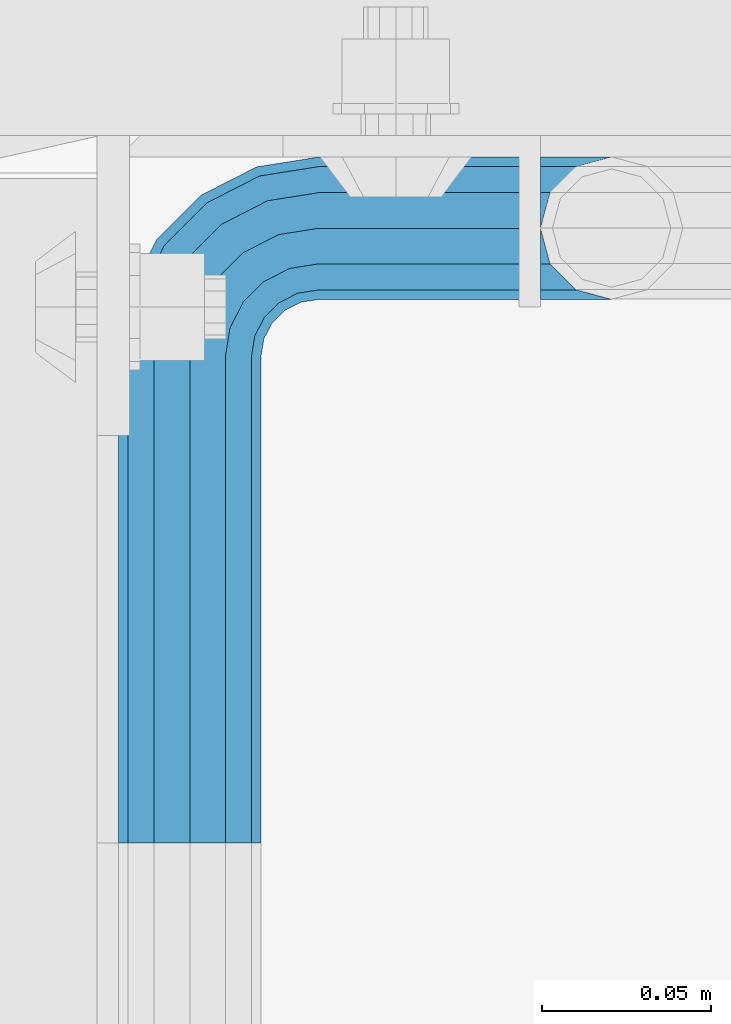
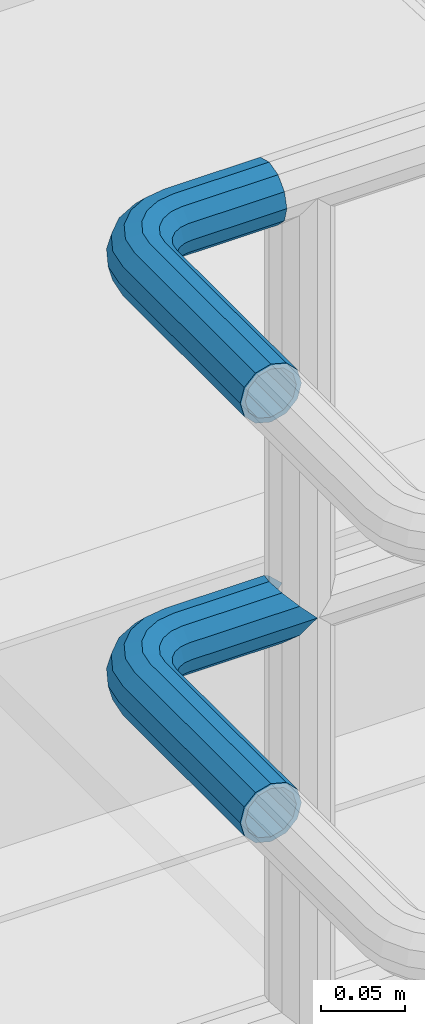
# One storey, part 1116 of 1876: 2 beams, 1 element without a shape of its own.
"""IFC2X3 building model written with IfcOpenShell, lengths in millimetres."""

from ifc_helpers import new_model, si_unit, frame, origin_with_axes, place, context, subcontext, project, spatial, faceted_brep, material, type_object, element, aggregate, save


model = new_model("IFC2X3")

# Units and contexts
model_context = context("Model", 3, precision=1e-05, world=origin_with_axes())
body_context = subcontext(model_context, "Body", "Model", "MODEL_VIEW")
ifc_project = project(units=[si_unit("LENGTHUNIT", "METRE", prefix="MILLI"), si_unit("AREAUNIT", "SQUARE_METRE"), si_unit("VOLUMEUNIT", "CUBIC_METRE"), si_unit("MASSUNIT", "GRAM", prefix="KILO"), si_unit("TIMEUNIT", "SECOND"), si_unit("PLANEANGLEUNIT", "RADIAN"), si_unit("SOLIDANGLEUNIT", "STERADIAN"), si_unit("THERMODYNAMICTEMPERATUREUNIT", "DEGREE_CELSIUS"), si_unit("LUMINOUSINTENSITYUNIT", "LUMEN")], contexts=[model_context])

# Site, building, storey
site_placement = place(None, origin_with_axes())
site = spatial("IfcSite", under=ifc_project, at=site_placement, CompositionType="ELEMENT")
building_placement = place(site_placement, origin_with_axes())
building = spatial("IfcBuilding", under=site, at=building_placement, Name="Undefined", CompositionType="ELEMENT")
storey_placement = place(building_placement, origin_with_axes())
storey = spatial("IfcBuildingStorey", under=building, at=storey_placement, Name="Undefined", CompositionType="ELEMENT", Elevation=0.0)

# Assembly, beams
assembly_placement = place(storey_placement, origin_with_axes())
assembly = element("IfcElementAssembly", 1, at=assembly_placement, inside=storey, Name="HANDRAIL", AssemblyPlace="NOTDEFINED", PredefinedType="RIGID_FRAME")
ifc_material = material()
beam_type = type_object("IfcBeamType", Name="PIPE1-1/4STD", PredefinedType="NOTDEFINED")
beam_1_placement = place(assembly_placement, frame((5666.23343150122, -11563.31485742, 8785.225), z_axis=(0.0, 0.0, -1.0), x_axis=(0.0, 1.0, 0.0)))
beam_1 = element("IfcBeam", 2, at=beam_1_placement, type_object=beam_type, material=ifc_material, Name="HANDRAIL", ObjectType="PIPE1-1/4STD", context=body_context, shape_type="Brep", body=[
    faceted_brep([(192.588302246095, 106.710451704997, 18.2575475625836), (192.588309811317, 106.710451704997, 13.3999536615011), (190.810302246095, 106.234036013759, 15.1779612267255), (182.047302246094, 103.88599926758, 17.5259999999998), (182.047302246094, 103.88599926758, 21.0820000000003), (173.284302246095, 106.23404006795, 15.1779612267255), (171.506309811319, 106.710451704997, 13.3999687919495), (171.506302246094, 106.710451704997, 18.2575475625836), (163.78975468351, 114.42699926758, 10.5409999999993), (163.78975468351, 114.42699926758, -10.5409999999993), (160.965302246093, 124.968002319336, 0.0), (166.869341019368, 111.347420496947, 8.76300000000083), (164.521302246094, 113.69545927022, 0.0), (166.869341019368, 111.347420496947, -8.76300000000083), (171.506309811319, 106.710451704997, -13.3999687919495), (171.506302246094, 106.710451704997, -18.2575475625836), (182.047302246094, 103.88599926758, -17.5259999999998), (182.047302246094, 103.88599926758, -21.0820000000003), (173.284302246095, 106.23404006795, -15.1779612267255), (192.588309811317, 106.710451704997, -13.3999536615011), (192.588302246095, 106.710451704997, -18.2575475625836), (190.810302246095, 106.234036013759, -15.1779612267255), (203.129309811318, 124.96799926758, 0.0), (200.304849808677, 114.42699926758, -10.5409999999993), (200.304849808677, 114.42699926758, 10.5409999999993), (197.225263472819, 111.347405366499, -8.76300000000083), (199.573302246094, 113.695444139772, 0.0), (197.225263472819, 111.347405366499, 8.76300000000083), (0.0, -18.2575475625836, -10.5409999999993), (0.0, -10.5410000000002, -18.2575475625836), (143.947303771973, -10.5409999999983, -18.2575475625836), (143.947303771973, -18.2575475625817, -10.5409999999993), (-4.28826751885936e-09, 0.0, -21.0820000000003), (143.947303771973, 1.81898940354586e-12, -21.0820000000003), (0.0, 10.5410000000002, -18.2575475625836), (143.947303771973, 10.5410000000011, -18.2575475625836), (0.0, 18.2575475625836, -10.5409999999993), (143.947303771973, 18.2575475625854, -10.5409999999993), (9.09494701772928e-13, 21.0820000000003, 0.0), (143.947303771973, 21.0820000000012, 0.0), (0.0, 18.2575475625836, 10.5409999999993), (143.947303771973, 18.2575475625854, 10.5409999999993), (0.0, 10.5410000000002, 18.2575475625836), (143.947303771973, 10.5410000000011, 18.2575475625836), (0.0, 0.0, 21.0820000000003), (143.947303771973, 1.81898940354586e-12, 21.0820000000003), (0.0, -10.5410000000002, 18.2575475625836), (143.947303771973, -10.5409999999983, 18.2575475625836), (0.0, -18.2575475625836, 10.5409999999993), (143.947303771973, -18.2575475625817, 10.5409999999993), (9.09494701772928e-13, -21.0820000000003, 0.0), (143.947303771973, -21.0819999999985, 0.0), (162.235547061553, -18.1854268220586, 0.0), (161.362743258587, -15.4992129264883, 10.5409999999993), (158.978198923845, -8.16034008379211, 18.2575475625836), (155.720850786138, 1.86474665447531, 21.0820000000003), (152.463502648432, 11.8898333927418, 18.2575475625836), (150.07895831369, 19.228706235438, 10.5409999999993), (149.206154510724, 21.9149201310092, 0.0), (150.07895831369, 19.2287062354389, -10.5409999999993), (152.463502648432, 11.8898333927418, -18.2575475625836), (155.720850786138, 1.86474665447531, -21.0820000000003), (158.978198923845, -8.16034008379211, -18.2575475625836), (161.362743258587, -15.4992129264883, -10.5409999999993), (163.789754683512, 38.0999984741229, -10.5409999999993), (160.965302246095, 38.0999984741229, 0.0), (163.789754683512, 38.0999984741229, 10.5409999999993), (171.506302246096, 38.0999984741229, 18.2575475625836), (182.047302246096, 38.099998474122, 21.0820000000003), (192.588302246097, 38.099998474122, 18.2575475625836), (200.304849808679, 38.099998474122, 10.5409999999993), (203.129302246094, 38.0999984741229, 0.0), (182.047302246096, 38.099998474122, -21.0820000000003), (171.506302246096, 38.0999984741229, -18.2575475625836), (192.588302246095, 38.099998474122, -18.2575475625836), (200.304849808679, 38.099998474122, -10.5409999999993), (162.818596010658, 31.9683439324062, -10.5409999999993), (170.157468853355, 29.5837995976653, -18.2575475625836), (160.132382115087, 32.841147735372, 0.0), (162.818596010658, 31.9683439324062, 10.5409999999993), (170.157468853355, 29.5837995976653, 18.2575475625836), (180.182555591622, 26.3264514599587, 21.0820000000003), (190.207642329889, 23.069103322252, 18.2575475625836), (197.546515172586, 20.6845589875102, 10.5409999999993), (200.232729068157, 19.8117551845444, 0.0), (197.546515172586, 20.6845589875102, -10.5409999999993), (190.207642329889, 23.069103322252, -18.2575475625836), (180.182555591622, 26.3264514599587, -21.0820000000003), (166.243001885488, 21.9012256030801, -18.2575475625836), (174.770850023195, 15.7053812586637, -21.0820000000003), (160.000183769456, 26.436898458981, -10.5409999999993), (157.715153747784, 28.0970699474965, 0.0), (160.000183769456, 26.436898458981, 10.5409999999993), (166.243001885488, 21.9012256030801, 18.2575475625836), (174.770850023195, 15.7053812586637, 21.0820000000003), (183.298698160899, 9.50953691424729, 18.2575475625836), (189.541516276931, 4.97386405834641, 10.5409999999993), (191.826546298606, 3.31369256983089, 0.0), (189.541516276931, 4.97386405834641, -10.5409999999993), (183.298698160899, 9.50953691424729, -18.2575475625836), (166.341920987434, 7.27645222290266, -21.0820000000003), (172.53776533185, -1.25139591480183, -18.2575475625836), (160.146076643017, 15.8043003606081, -18.2575475625836), (155.610403787116, 22.0471184766402, -10.5409999999993), (153.950232298601, 24.3321484983135, 0.0), (155.610403787116, 22.0471184766402, 10.5409999999993), (160.146076643017, 15.8043003606081, 18.2575475625836), (166.341920987434, 7.27645222290266, 21.0820000000003), (172.53776533185, -1.25139591480183, 18.2575475625836), (177.07343818775, -7.49421403083397, 10.5409999999993), (178.733609676266, -9.77924405250724, 0.0), (177.07343818775, -7.49421403083397, -10.5409999999993), (0.0, -15.1779612267264, -8.76300000000083), (0.0, -8.76299999999992, -15.1779612267255), (0.0, 0.0, -17.5259999999998), (0.0, 8.76299999999992, -15.1779612267255), (0.0, 15.1779612267264, -8.76300000000083), (0.0, 17.5259999999998, 0.0), (0.0, 15.1779612267264, 8.76300000000083), (0.0, 8.76299999999992, 15.1779612267255), (0.0, 0.0, 17.5259999999998), (0.0, -8.76299999999992, 15.1779612267255), (0.0, -15.1779612267264, 8.76300000000083), (0.0, -17.5259999999998, 0.0), (143.947303771973, -8.7629999999981, 15.1779612267255), (143.947303771973, -15.1779612267246, 8.76300000000083), (143.947303771973, -17.5259999999989, 0.0), (143.947303771973, -15.1779612267246, -8.76300000000083), (143.947303771973, -8.76299999999901, -15.1779612267255), (143.947303771973, 1.81898940354586e-12, -17.5259999999998), (143.947303771973, 8.76300000000174, -15.1779612267255), (143.947303771973, 15.1779612267273, -8.76300000000083), (143.947303771973, 17.5260000000017, 0.0), (143.947303771973, 15.1779612267273, 8.76300000000083), (143.947303771973, 8.76300000000174, 15.1779612267255), (143.947303771973, 1.81898940354586e-12, 17.5259999999998), (155.720850786138, 1.86474665447531, 17.5259999999998), (158.428766707846, -6.46936159781944, 15.1779612267255), (160.411098745162, -12.5703522742779, 8.76300000000083), (161.136682629554, -14.8034698501133, 0.0), (160.411098745162, -12.5703522742779, -8.76300000000083), (158.428766707846, -6.46936159781944, -15.1779612267255), (155.720850786138, 1.86474665447531, -17.5259999999998), (153.01293486443, 10.1988549067692, -15.1779612267255), (151.030602827115, 16.2998455832276, -8.76300000000083), (150.305018942723, 18.5329631590639, 0.0), (151.030602827115, 16.2998455832276, 8.76300000000083), (153.01293486443, 10.1988549067692, 15.1779612267255), (161.191158821593, 14.3658681446095, 15.1779612267255), (166.341920987434, 7.27645222290266, 17.5259999999998), (157.420539218494, 19.5556807952871, 8.76300000000083), (156.040396655753, 21.4552840663164, 0.0), (157.420539218494, 19.5556807952871, -8.76300000000083), (161.191158821593, 14.3658681446095, -15.1779612267255), (166.341920987434, 7.27645222290266, -17.5259999999998), (171.492683153274, 0.187036301196713, -15.1779612267255), (175.263302756372, -5.00277634948088, -8.76300000000083), (176.643445319114, -6.90237962051015, 0.0), (175.263302756372, -5.00277634948088, 8.76300000000083), (171.492683153274, 0.187036301196713, 15.1779612267255), (174.770850023195, 15.7053812586637, 17.5259999999998), (181.860265944901, 10.5546190928235, 15.1779612267255), (167.681434101487, 20.8561434245039, 15.1779612267255), (162.49162145081, 24.6267630276025, 8.76300000000083), (160.592018179781, 26.0069055903441, 0.0), (162.49162145081, 24.6267630276025, -8.76300000000083), (167.681434101487, 20.8561434245039, -15.1779612267255), (174.770850023195, 15.7053812586637, -17.5259999999998), (181.860265944901, 10.5546190928235, -15.1779612267255), (187.050078595577, 6.78399948972492, -8.76300000000083), (188.949681866608, 5.40385692698328, 0.0), (187.050078595577, 6.78399948972492, 8.76300000000083), (188.516663843917, 23.6185355382504, 15.1779612267255), (194.617654520374, 21.6362035009352, 8.76300000000083), (180.182555591622, 26.3264514599587, 17.5259999999998), (171.848447339327, 29.0343673816669, 15.1779612267255), (165.74745666287, 31.0166994189813, 8.76300000000083), (163.514339087033, 31.7422833033743, 0.0), (165.74745666287, 31.0166994189813, -8.76300000000083), (171.848447339327, 29.0343673816669, -15.1779612267255), (180.182555591622, 26.3264514599587, -17.5259999999998), (188.516663843917, 23.6185355382504, -15.1779612267255), (194.617654520374, 21.6362035009352, -8.76300000000083), (196.850772096212, 20.9106196165421, 0.0), (197.225263472821, 38.099998474122, 8.76300000000083), (199.573302246094, 38.0999984741229, 0.0), (190.810302246096, 38.099998474122, 15.1779612267255), (182.047302246096, 38.099998474122, 17.5259999999998), (173.284302246095, 38.099998474122, 15.1779612267255), (166.86934101937, 38.0999984741229, 8.76300000000083), (164.521302246096, 38.0999984741229, 0.0), (166.86934101937, 38.0999984741229, -8.76300000000083), (173.284302246095, 38.099998474122, -15.1779612267255), (182.047302246096, 38.099998474122, -17.5259999999998), (190.810302246096, 38.099998474122, -15.1779612267255), (197.225263472821, 38.099998474122, -8.76300000000083)], [[[0, 1, 2, 3, 4]], [[4, 3, 5, 6, 7]], [[8, 9, 10]], [[7, 6, 11, 12, 13, 14, 15, 9, 8]], [[16, 17, 15, 14, 18]], [[19, 20, 17, 16, 21]], [[22, 23, 24]], [[24, 23, 20, 19, 25, 26, 27, 1, 0]], [[28, 29, 30, 31]], [[29, 32, 33, 30]], [[32, 34, 35, 33]], [[34, 36, 37, 35]], [[36, 38, 39, 37]], [[38, 40, 41, 39]], [[40, 42, 43, 41]], [[42, 44, 45, 43]], [[44, 46, 47, 45]], [[46, 48, 49, 47]], [[48, 50, 51, 49]], [[49, 51, 52, 53]], [[47, 49, 53, 54]], [[45, 47, 54, 55]], [[43, 45, 55, 56]], [[41, 43, 56, 57]], [[39, 41, 57, 58]], [[37, 39, 58, 59]], [[35, 37, 59, 60]], [[33, 35, 60, 61]], [[30, 33, 61, 62]], [[31, 30, 62, 63]], [[64, 65, 10, 9]], [[65, 66, 8, 10]], [[66, 67, 7, 8]], [[67, 68, 4, 7]], [[68, 69, 0, 4]], [[69, 70, 24, 0]], [[70, 71, 22, 24]], [[72, 73, 15, 17]], [[74, 72, 17, 20]], [[75, 74, 20, 23]], [[71, 75, 23, 22]], [[73, 64, 9, 15]], [[76, 64, 73, 77]], [[78, 65, 64, 76]], [[79, 66, 65, 78]], [[80, 67, 66, 79]], [[81, 68, 67, 80]], [[82, 69, 68, 81]], [[83, 70, 69, 82]], [[84, 71, 70, 83]], [[85, 75, 71, 84]], [[86, 74, 75, 85]], [[87, 72, 74, 86]], [[77, 73, 72, 87]], [[88, 77, 87, 89]], [[90, 76, 77, 88]], [[91, 78, 76, 90]], [[92, 79, 78, 91]], [[93, 80, 79, 92]], [[94, 81, 80, 93]], [[95, 82, 81, 94]], [[96, 83, 82, 95]], [[97, 84, 83, 96]], [[98, 85, 84, 97]], [[99, 86, 85, 98]], [[89, 87, 86, 99]], [[100, 89, 99, 101]], [[102, 88, 89, 100]], [[103, 90, 88, 102]], [[104, 91, 90, 103]], [[105, 92, 91, 104]], [[106, 93, 92, 105]], [[107, 94, 93, 106]], [[108, 95, 94, 107]], [[109, 96, 95, 108]], [[110, 97, 96, 109]], [[111, 98, 97, 110]], [[101, 99, 98, 111]], [[62, 101, 111, 63]], [[61, 100, 101, 62]], [[60, 102, 100, 61]], [[59, 103, 102, 60]], [[58, 104, 103, 59]], [[57, 105, 104, 58]], [[56, 106, 105, 57]], [[55, 107, 106, 56]], [[54, 108, 107, 55]], [[53, 109, 108, 54]], [[52, 110, 109, 53]], [[63, 111, 110, 52]], [[51, 31, 63, 52]], [[50, 28, 31, 51]], [[48, 46, 44, 42, 40, 38, 36, 34, 32, 29, 28, 50], [112, 113, 114, 115, 116, 117, 118, 119, 120, 121, 122, 123]], [[122, 121, 124, 125]], [[123, 122, 125, 126]], [[112, 123, 126, 127]], [[113, 112, 127, 128]], [[114, 113, 128, 129]], [[115, 114, 129, 130]], [[116, 115, 130, 131]], [[117, 116, 131, 132]], [[118, 117, 132, 133]], [[119, 118, 133, 134]], [[120, 119, 134, 135]], [[121, 120, 135, 124]], [[124, 135, 136, 137]], [[125, 124, 137, 138]], [[126, 125, 138, 139]], [[127, 126, 139, 140]], [[128, 127, 140, 141]], [[129, 128, 141, 142]], [[130, 129, 142, 143]], [[131, 130, 143, 144]], [[132, 131, 144, 145]], [[133, 132, 145, 146]], [[134, 133, 146, 147]], [[135, 134, 147, 136]], [[147, 148, 149, 136]], [[146, 150, 148, 147]], [[145, 151, 150, 146]], [[144, 152, 151, 145]], [[143, 153, 152, 144]], [[142, 154, 153, 143]], [[141, 155, 154, 142]], [[140, 156, 155, 141]], [[139, 157, 156, 140]], [[138, 158, 157, 139]], [[137, 159, 158, 138]], [[136, 149, 159, 137]], [[149, 160, 161, 159]], [[148, 162, 160, 149]], [[150, 163, 162, 148]], [[151, 164, 163, 150]], [[152, 165, 164, 151]], [[153, 166, 165, 152]], [[154, 167, 166, 153]], [[155, 168, 167, 154]], [[156, 169, 168, 155]], [[157, 170, 169, 156]], [[158, 171, 170, 157]], [[159, 161, 171, 158]], [[161, 172, 173, 171]], [[160, 174, 172, 161]], [[162, 175, 174, 160]], [[163, 176, 175, 162]], [[164, 177, 176, 163]], [[165, 178, 177, 164]], [[166, 179, 178, 165]], [[167, 180, 179, 166]], [[168, 181, 180, 167]], [[169, 182, 181, 168]], [[170, 183, 182, 169]], [[171, 173, 183, 170]], [[173, 184, 185, 183]], [[172, 186, 184, 173]], [[174, 187, 186, 172]], [[175, 188, 187, 174]], [[176, 189, 188, 175]], [[177, 190, 189, 176]], [[178, 191, 190, 177]], [[179, 192, 191, 178]], [[180, 193, 192, 179]], [[181, 194, 193, 180]], [[182, 195, 194, 181]], [[183, 185, 195, 182]], [[195, 185, 26, 25]], [[21, 194, 195, 25, 19]], [[193, 194, 21, 16]], [[192, 193, 16, 18]], [[13, 191, 192, 18, 14]], [[190, 191, 13, 12]], [[189, 190, 12, 11]], [[188, 189, 11, 6, 5]], [[187, 188, 5, 3]], [[186, 187, 3, 2]], [[184, 186, 2, 1, 27]], [[185, 184, 27, 26]]]),
])
beam_2_placement = place(assembly_placement, frame((5666.23343150122, -11563.31485742, 9090.025), z_axis=(0.0, 0.0, -1.0), x_axis=(0.0, 1.0, 0.0)))
beam_2 = element("IfcBeam", 3, at=beam_2_placement, type_object=beam_type, material=ifc_material, Name="HANDRAIL", ObjectType="PIPE1-1/4STD", context=body_context, shape_type="Brep", body=[
    faceted_brep([(9.09494701772928e-13, -21.0820000000003, 0.0), (0.0, -18.2575475625836, -10.5409999999993), (143.947303771973, -18.2575475625817, -10.5409999999993), (143.947303771973, -21.0819999999985, 0.0), (0.0, -10.5410000000002, -18.2575475625836), (143.947303771973, -10.5409999999983, -18.2575475625836), (-4.28826751885936e-09, 0.0, -21.0820000000003), (143.947303771973, 1.81898940354586e-12, -21.0820000000003), (0.0, 10.5410000000002, -18.2575475625836), (143.947303771973, 10.5410000000011, -18.2575475625836), (0.0, 18.2575475625836, -10.5409999999993), (143.947303771973, 18.2575475625854, -10.5409999999993), (9.09494701772928e-13, 21.0820000000003, 0.0), (143.947303771973, 21.0820000000012, 0.0), (0.0, 18.2575475625836, 10.5409999999993), (143.947303771973, 18.2575475625854, 10.5409999999993), (0.0, 10.5410000000002, 18.2575475625836), (143.947303771973, 10.5410000000011, 18.2575475625836), (0.0, 0.0, 21.0820000000003), (143.947303771973, 1.81898940354586e-12, 21.0820000000003), (0.0, -10.5410000000002, 18.2575475625836), (143.947303771973, -10.5409999999983, 18.2575475625836), (0.0, -18.2575475625836, 10.5409999999993), (143.947303771973, -18.2575475625817, 10.5409999999993), (0.0, -17.5259999999998, 0.0), (0.0, -15.1779612267264, 8.76300000000083), (143.947303771973, -15.1779612267246, 8.76300000000083), (143.947303771973, -17.5259999999989, 0.0), (0.0, -8.76299999999992, 15.1779612267255), (143.947303771973, -8.7629999999981, 15.1779612267255), (0.0, 0.0, 17.5259999999998), (143.947303771973, 1.81898940354586e-12, 17.5259999999998), (0.0, 8.76299999999992, 15.1779612267255), (143.947303771973, 8.76300000000174, 15.1779612267255), (0.0, 15.1779612267264, 8.76300000000083), (143.947303771973, 15.1779612267273, 8.76300000000083), (0.0, 17.5259999999998, 0.0), (143.947303771973, 17.5260000000017, 0.0), (0.0, 15.1779612267264, -8.76300000000083), (143.947303771973, 15.1779612267273, -8.76300000000083), (0.0, 8.76299999999992, -15.1779612267255), (143.947303771973, 8.76300000000174, -15.1779612267255), (0.0, 0.0, -17.5259999999998), (143.947303771973, 1.81898940354586e-12, -17.5259999999998), (0.0, -8.76299999999992, -15.1779612267255), (143.947303771973, -8.76299999999901, -15.1779612267255), (0.0, -15.1779612267264, -8.76300000000083), (143.947303771973, -15.1779612267246, -8.76300000000083), (162.235547061553, -18.1854268220586, 0.0), (161.362743258587, -15.4992129264883, 10.5409999999993), (158.978198923845, -8.16034008379211, 18.2575475625836), (155.720850786138, 1.86474665447531, 21.0820000000003), (152.463502648432, 11.8898333927418, 18.2575475625836), (150.07895831369, 19.228706235438, 10.5409999999993), (149.206154510724, 21.9149201310092, 0.0), (150.07895831369, 19.2287062354389, -10.5409999999993), (152.463502648432, 11.8898333927418, -18.2575475625836), (155.720850786138, 1.86474665447531, -21.0820000000003), (158.978198923845, -8.16034008379211, -18.2575475625836), (161.362743258587, -15.4992129264883, -10.5409999999993), (161.136682629554, -14.8034698501133, 0.0), (160.411098745162, -12.5703522742779, -8.76300000000083), (158.428766707846, -6.46936159781944, -15.1779612267255), (155.720850786138, 1.86474665447531, -17.5259999999998), (153.01293486443, 10.1988549067692, -15.1779612267255), (151.030602827115, 16.2998455832276, -8.76300000000083), (150.305018942723, 18.5329631590639, 0.0), (151.030602827115, 16.2998455832276, 8.76300000000083), (153.01293486443, 10.1988549067692, 15.1779612267255), (155.720850786138, 1.86474665447531, 17.5259999999998), (158.428766707846, -6.46936159781944, 15.1779612267255), (160.411098745162, -12.5703522742779, 8.76300000000083), (172.53776533185, -1.25139591480183, -18.2575475625836), (177.07343818775, -7.49421403083397, -10.5409999999993), (166.341920987434, 7.27645222290266, -21.0820000000003), (160.146076643017, 15.8043003606081, -18.2575475625836), (155.610403787116, 22.0471184766402, -10.5409999999993), (153.950232298601, 24.3321484983135, 0.0), (155.610403787116, 22.0471184766402, 10.5409999999993), (160.146076643017, 15.8043003606081, 18.2575475625836), (166.341920987434, 7.27645222290266, 21.0820000000003), (172.53776533185, -1.25139591480183, 18.2575475625836), (177.07343818775, -7.49421403083397, 10.5409999999993), (178.733609676266, -9.77924405250724, 0.0), (175.263302756372, -5.00277634948088, 8.76300000000083), (176.643445319114, -6.90237962051015, 0.0), (171.492683153274, 0.187036301196713, 15.1779612267255), (166.341920987434, 7.27645222290266, 17.5259999999998), (161.191158821593, 14.3658681446095, 15.1779612267255), (157.420539218494, 19.5556807952871, 8.76300000000083), (156.040396655753, 21.4552840663164, 0.0), (157.420539218494, 19.5556807952871, -8.76300000000083), (161.191158821593, 14.3658681446095, -15.1779612267255), (166.341920987434, 7.27645222290266, -17.5259999999998), (171.492683153274, 0.187036301196713, -15.1779612267255), (175.263302756372, -5.00277634948088, -8.76300000000083), (183.298698160899, 9.50953691424729, -18.2575475625836), (189.541516276931, 4.97386405834641, -10.5409999999993), (174.770850023195, 15.7053812586637, -21.0820000000003), (166.243001885488, 21.9012256030801, -18.2575475625836), (160.000183769456, 26.436898458981, -10.5409999999993), (157.715153747784, 28.0970699474965, 0.0), (160.000183769456, 26.436898458981, 10.5409999999993), (166.243001885488, 21.9012256030801, 18.2575475625836), (174.770850023195, 15.7053812586637, 21.0820000000003), (183.298698160899, 9.50953691424729, 18.2575475625836), (189.541516276931, 4.97386405834641, 10.5409999999993), (191.826546298606, 3.31369256983089, 0.0), (187.050078595577, 6.78399948972492, 8.76300000000083), (188.949681866608, 5.40385692698328, 0.0), (181.860265944901, 10.5546190928235, 15.1779612267255), (174.770850023195, 15.7053812586637, 17.5259999999998), (167.681434101487, 20.8561434245039, 15.1779612267255), (162.49162145081, 24.6267630276025, 8.76300000000083), (160.592018179781, 26.0069055903441, 0.0), (162.49162145081, 24.6267630276025, -8.76300000000083), (167.681434101487, 20.8561434245039, -15.1779612267255), (174.770850023195, 15.7053812586637, -17.5259999999998), (181.860265944901, 10.5546190928235, -15.1779612267255), (187.050078595577, 6.78399948972492, -8.76300000000083), (190.207642329889, 23.069103322252, -18.2575475625836), (197.546515172586, 20.6845589875102, -10.5409999999993), (180.182555591622, 26.3264514599587, -21.0820000000003), (170.157468853355, 29.5837995976653, -18.2575475625836), (162.818596010658, 31.9683439324062, -10.5409999999993), (160.132382115087, 32.841147735372, 0.0), (162.818596010658, 31.9683439324062, 10.5409999999993), (170.157468853355, 29.5837995976653, 18.2575475625836), (180.182555591622, 26.3264514599587, 21.0820000000003), (190.207642329889, 23.069103322252, 18.2575475625836), (197.546515172586, 20.6845589875102, 10.5409999999993), (200.232729068157, 19.8117551845444, 0.0), (194.617654520374, 21.6362035009352, 8.76300000000083), (196.850772096212, 20.9106196165421, 0.0), (188.516663843917, 23.6185355382504, 15.1779612267255), (180.182555591622, 26.3264514599587, 17.5259999999998), (171.848447339327, 29.0343673816669, 15.1779612267255), (165.74745666287, 31.0166994189813, 8.76300000000083), (163.514339087033, 31.7422833033743, 0.0), (165.74745666287, 31.0166994189813, -8.76300000000083), (171.848447339327, 29.0343673816669, -15.1779612267255), (180.182555591622, 26.3264514599587, -17.5259999999998), (188.516663843917, 23.6185355382504, -15.1779612267255), (194.617654520374, 21.6362035009352, -8.76300000000083), (192.588302246095, 38.099998474122, -18.2575475625836), (200.304849808679, 38.099998474122, -10.5409999999993), (182.047302246096, 38.099998474122, -21.0820000000003), (171.506302246096, 38.0999984741229, -18.2575475625836), (163.789754683512, 38.0999984741229, -10.5409999999993), (160.965302246095, 38.0999984741229, 0.0), (163.789754683512, 38.0999984741229, 10.5409999999993), (171.506302246096, 38.0999984741229, 18.2575475625836), (182.047302246096, 38.099998474122, 21.0820000000003), (192.588302246097, 38.099998474122, 18.2575475625836), (200.304849808679, 38.099998474122, 10.5409999999993), (203.129302246094, 38.0999984741229, 0.0), (197.225263472821, 38.099998474122, 8.76300000000083), (199.573302246094, 38.0999984741229, 0.0), (190.810302246096, 38.099998474122, 15.1779612267255), (182.047302246096, 38.099998474122, 17.5259999999998), (173.284302246095, 38.099998474122, 15.1779612267255), (166.86934101937, 38.0999984741229, 8.76300000000083), (164.521302246096, 38.0999984741229, 0.0), (166.86934101937, 38.0999984741229, -8.76300000000083), (173.284302246095, 38.099998474122, -15.1779612267255), (182.047302246096, 38.099998474122, -17.5259999999998), (190.810302246096, 38.099998474122, -15.1779612267255), (197.225263472821, 38.099998474122, -8.76300000000083), (200.304849808677, 103.933624267578, -10.5409999999993), (203.129302246094, 103.933624267578, 0.0), (192.588302246093, 103.933624267578, -18.2575475625836), (182.047302246094, 103.933624267578, -21.0820000000003), (171.506302246094, 103.933624267578, -18.2575475625836), (163.78975468351, 103.933624267578, -10.5409999999993), (160.965302246093, 103.933624267578, 0.0), (163.78975468351, 103.933624267578, 10.5409999999993), (171.506302246094, 103.933624267578, 18.2575475625836), (182.047302246094, 103.933624267578, 21.0820000000003), (192.588302246093, 103.933624267578, 18.2575475625836), (200.304849808677, 103.933624267578, 10.5409999999993), (197.225263472819, 103.933624267578, 8.76300000000083), (199.573302246094, 103.933624267578, 0.0), (190.810302246095, 103.933624267578, 15.1779612267255), (182.047302246094, 103.933624267578, 17.5259999999998), (173.284302246093, 103.933624267578, 15.1779612267255), (166.869341019368, 103.933624267578, 8.76300000000083), (164.521302246094, 103.933624267578, 0.0), (166.869341019368, 103.933624267578, -8.76300000000083), (173.284302246093, 103.933624267578, -15.1779612267255), (182.047302246094, 103.933624267578, -17.5259999999998), (190.810302246095, 103.933624267578, -15.1779612267255), (197.225263472819, 103.933624267578, -8.76300000000083)], [[[0, 1, 2, 3]], [[1, 4, 5, 2]], [[4, 6, 7, 5]], [[6, 8, 9, 7]], [[8, 10, 11, 9]], [[10, 12, 13, 11]], [[12, 14, 15, 13]], [[14, 16, 17, 15]], [[16, 18, 19, 17]], [[18, 20, 21, 19]], [[20, 22, 23, 21]], [[22, 0, 3, 23]], [[24, 25, 26, 27]], [[25, 28, 29, 26]], [[28, 30, 31, 29]], [[30, 32, 33, 31]], [[32, 34, 35, 33]], [[34, 36, 37, 35]], [[36, 38, 39, 37]], [[38, 40, 41, 39]], [[40, 42, 43, 41]], [[42, 44, 45, 43]], [[44, 46, 47, 45]], [[46, 24, 27, 47]], [[22, 20, 18, 16, 14, 12, 10, 8, 6, 4, 1, 0], [46, 44, 42, 40, 38, 36, 34, 32, 30, 28, 25, 24]], [[23, 3, 48, 49]], [[21, 23, 49, 50]], [[19, 21, 50, 51]], [[17, 19, 51, 52]], [[15, 17, 52, 53]], [[13, 15, 53, 54]], [[11, 13, 54, 55]], [[9, 11, 55, 56]], [[7, 9, 56, 57]], [[5, 7, 57, 58]], [[2, 5, 58, 59]], [[3, 2, 59, 48]], [[47, 27, 60, 61]], [[45, 47, 61, 62]], [[43, 45, 62, 63]], [[41, 43, 63, 64]], [[39, 41, 64, 65]], [[37, 39, 65, 66]], [[35, 37, 66, 67]], [[33, 35, 67, 68]], [[31, 33, 68, 69]], [[29, 31, 69, 70]], [[26, 29, 70, 71]], [[27, 26, 71, 60]], [[58, 72, 73, 59]], [[57, 74, 72, 58]], [[56, 75, 74, 57]], [[55, 76, 75, 56]], [[54, 77, 76, 55]], [[53, 78, 77, 54]], [[52, 79, 78, 53]], [[51, 80, 79, 52]], [[50, 81, 80, 51]], [[49, 82, 81, 50]], [[48, 83, 82, 49]], [[59, 73, 83, 48]], [[71, 84, 85, 60]], [[70, 86, 84, 71]], [[69, 87, 86, 70]], [[68, 88, 87, 69]], [[67, 89, 88, 68]], [[66, 90, 89, 67]], [[65, 91, 90, 66]], [[64, 92, 91, 65]], [[63, 93, 92, 64]], [[62, 94, 93, 63]], [[61, 95, 94, 62]], [[60, 85, 95, 61]], [[72, 96, 97, 73]], [[74, 98, 96, 72]], [[75, 99, 98, 74]], [[76, 100, 99, 75]], [[77, 101, 100, 76]], [[78, 102, 101, 77]], [[79, 103, 102, 78]], [[80, 104, 103, 79]], [[81, 105, 104, 80]], [[82, 106, 105, 81]], [[83, 107, 106, 82]], [[73, 97, 107, 83]], [[84, 108, 109, 85]], [[86, 110, 108, 84]], [[87, 111, 110, 86]], [[88, 112, 111, 87]], [[89, 113, 112, 88]], [[90, 114, 113, 89]], [[91, 115, 114, 90]], [[92, 116, 115, 91]], [[93, 117, 116, 92]], [[94, 118, 117, 93]], [[95, 119, 118, 94]], [[85, 109, 119, 95]], [[96, 120, 121, 97]], [[98, 122, 120, 96]], [[99, 123, 122, 98]], [[100, 124, 123, 99]], [[101, 125, 124, 100]], [[102, 126, 125, 101]], [[103, 127, 126, 102]], [[104, 128, 127, 103]], [[105, 129, 128, 104]], [[106, 130, 129, 105]], [[107, 131, 130, 106]], [[97, 121, 131, 107]], [[108, 132, 133, 109]], [[110, 134, 132, 108]], [[111, 135, 134, 110]], [[112, 136, 135, 111]], [[113, 137, 136, 112]], [[114, 138, 137, 113]], [[115, 139, 138, 114]], [[116, 140, 139, 115]], [[117, 141, 140, 116]], [[118, 142, 141, 117]], [[119, 143, 142, 118]], [[109, 133, 143, 119]], [[120, 144, 145, 121]], [[122, 146, 144, 120]], [[123, 147, 146, 122]], [[124, 148, 147, 123]], [[125, 149, 148, 124]], [[126, 150, 149, 125]], [[127, 151, 150, 126]], [[128, 152, 151, 127]], [[129, 153, 152, 128]], [[130, 154, 153, 129]], [[131, 155, 154, 130]], [[121, 145, 155, 131]], [[132, 156, 157, 133]], [[134, 158, 156, 132]], [[135, 159, 158, 134]], [[136, 160, 159, 135]], [[137, 161, 160, 136]], [[138, 162, 161, 137]], [[139, 163, 162, 138]], [[140, 164, 163, 139]], [[141, 165, 164, 140]], [[142, 166, 165, 141]], [[143, 167, 166, 142]], [[133, 157, 167, 143]], [[155, 145, 168, 169]], [[145, 144, 170, 168]], [[144, 146, 171, 170]], [[146, 147, 172, 171]], [[147, 148, 173, 172]], [[148, 149, 174, 173]], [[149, 150, 175, 174]], [[150, 151, 176, 175]], [[151, 152, 177, 176]], [[152, 153, 178, 177]], [[153, 154, 179, 178]], [[154, 155, 169, 179]], [[157, 156, 180, 181]], [[156, 158, 182, 180]], [[158, 159, 183, 182]], [[159, 160, 184, 183]], [[160, 161, 185, 184]], [[161, 162, 186, 185]], [[162, 163, 187, 186]], [[163, 164, 188, 187]], [[164, 165, 189, 188]], [[165, 166, 190, 189]], [[166, 167, 191, 190]], [[167, 157, 181, 191]], [[170, 171, 172, 173, 174, 175, 176, 177, 178, 179, 169, 168], [182, 183, 184, 185, 186, 187, 188, 189, 190, 191, 181, 180]]]),
])
aggregate(assembly, [beam_1, beam_2])

save(model, "model.ifc")
